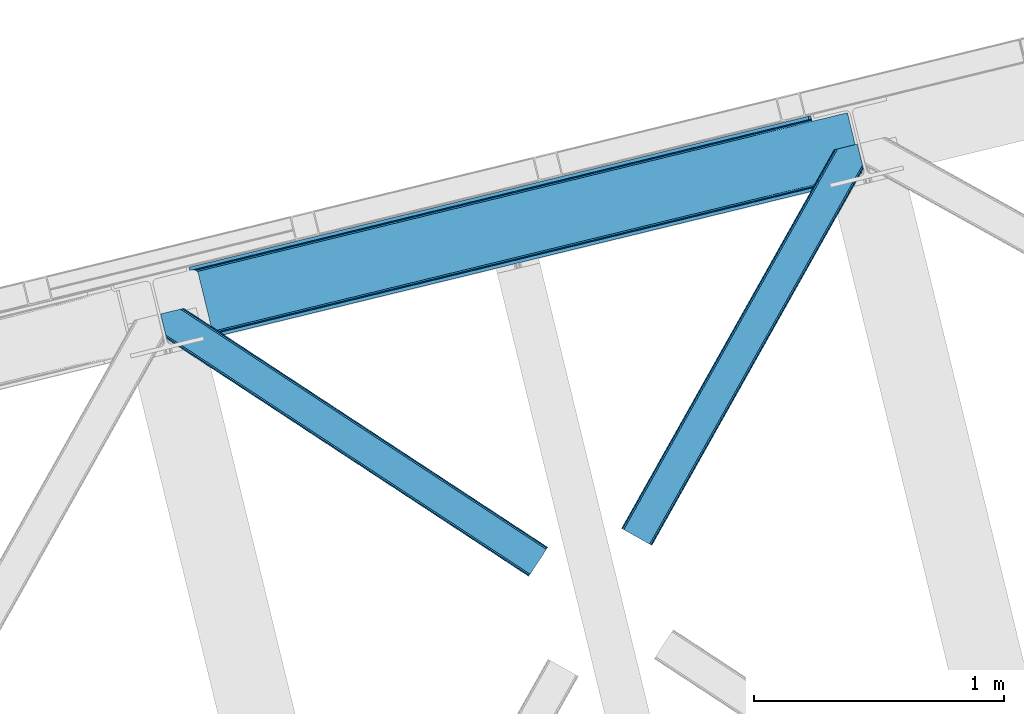
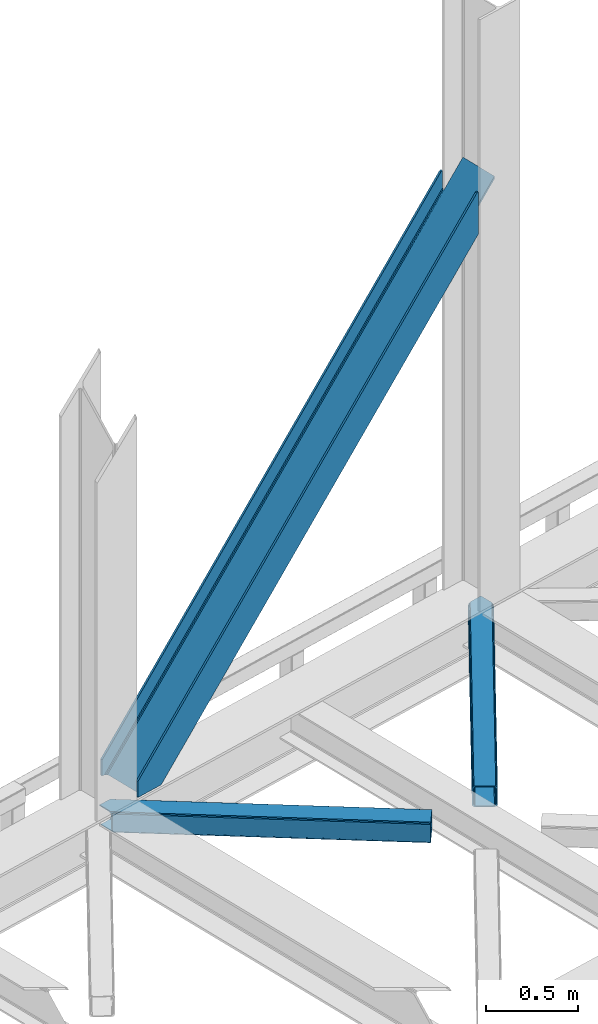
# One storey, part 80 of 93: 3 members.
"""IFC4 building model written with IfcOpenShell, lengths in millimetres."""

from ifc_helpers import new_model, entity, si_unit, converted_unit, derived_unit, direction, frame, origin, place, context, subcontext, project, spatial, triangles, polygons, type_object, element, save


model = new_model("IFC4")

# Units and contexts
model_context = context("Model", 3, precision=0.01, world=origin(), true_north=direction((6.12303176911189e-17, 1.0)))
plan_context = context("Plan", 3, precision=0.01, world=origin(), true_north=direction((6.12303176911189e-17, 1.0)))
body_context = subcontext(model_context, "Body", "Model", "MODEL_VIEW")
ifc_project = project(units=[si_unit("LENGTHUNIT", "METRE", prefix="MILLI"), si_unit("AREAUNIT", "SQUARE_METRE"), si_unit("VOLUMEUNIT", "CUBIC_METRE"), converted_unit("PLANEANGLEUNIT", "DEGREE", entity("IfcRatioMeasure", 0.0174532925199433), si_unit("PLANEANGLEUNIT", "RADIAN"), dimensions=[0, 0, 0, 0, 0, 0, 0]), si_unit("MASSUNIT", "GRAM", prefix="KILO"), derived_unit("MASSDENSITYUNIT", [(si_unit("MASSUNIT", "GRAM", prefix="KILO"), 1), (si_unit("LENGTHUNIT", "METRE"), -3)]), derived_unit("MOMENTOFINERTIAUNIT", [(si_unit("LENGTHUNIT", "METRE"), 4)]), si_unit("TIMEUNIT", "SECOND"), si_unit("FREQUENCYUNIT", "HERTZ"), si_unit("THERMODYNAMICTEMPERATUREUNIT", "DEGREE_CELSIUS"), derived_unit("THERMALTRANSMITTANCEUNIT", [(si_unit("MASSUNIT", "GRAM", prefix="KILO"), 1), (si_unit("THERMODYNAMICTEMPERATUREUNIT", "KELVIN"), -1), (si_unit("TIMEUNIT", "SECOND"), -3)]), derived_unit("VOLUMETRICFLOWRATEUNIT", [(si_unit("LENGTHUNIT", "METRE"), 3), (si_unit("TIMEUNIT", "SECOND"), -1)]), derived_unit("MASSFLOWRATEUNIT", [(si_unit("MASSUNIT", "GRAM", prefix="KILO"), 1), (si_unit("TIMEUNIT", "SECOND"), -1)]), derived_unit("ROTATIONALFREQUENCYUNIT", [(si_unit("TIMEUNIT", "SECOND"), -1)]), si_unit("ELECTRICCURRENTUNIT", "AMPERE"), si_unit("ELECTRICVOLTAGEUNIT", "VOLT"), si_unit("POWERUNIT", "WATT"), si_unit("FORCEUNIT", "NEWTON", prefix="KILO"), si_unit("ILLUMINANCEUNIT", "LUX"), si_unit("LUMINOUSFLUXUNIT", "LUMEN"), si_unit("LUMINOUSINTENSITYUNIT", "CANDELA"), derived_unit("USERDEFINED", [(si_unit("MASSUNIT", "GRAM", prefix="KILO"), -1), (si_unit("LENGTHUNIT", "METRE"), -2), (si_unit("TIMEUNIT", "SECOND"), 3), (si_unit("LUMINOUSFLUXUNIT", "LUMEN"), 1)]), derived_unit("LINEARVELOCITYUNIT", [(si_unit("LENGTHUNIT", "METRE"), 1), (si_unit("TIMEUNIT", "SECOND"), -1)]), si_unit("PRESSUREUNIT", "PASCAL"), derived_unit("USERDEFINED", [(si_unit("LENGTHUNIT", "METRE"), -2), (si_unit("MASSUNIT", "GRAM", prefix="KILO"), 1), (si_unit("TIMEUNIT", "SECOND"), -2)]), derived_unit("LINEARFORCEUNIT", [(si_unit("MASSUNIT", "GRAM", prefix="KILO"), 1), (si_unit("LENGTHUNIT", "METRE"), 1), (si_unit("TIMEUNIT", "SECOND"), -2), (si_unit("LENGTHUNIT", "METRE"), -1)]), derived_unit("PLANARFORCEUNIT", [(si_unit("MASSUNIT", "GRAM", prefix="KILO"), 1), (si_unit("LENGTHUNIT", "METRE"), 1), (si_unit("TIMEUNIT", "SECOND"), -2), (si_unit("LENGTHUNIT", "METRE"), -2)])], contexts=[model_context, plan_context])

# Site, building, storey
site_placement = place(None, origin())
site = spatial("IfcSite", under=ifc_project, at=site_placement, CompositionType="ELEMENT")
building_placement = place(site_placement, origin())
building = spatial("IfcBuilding", under=site, at=building_placement, CompositionType="ELEMENT")
storey_placement = place(building_placement, frame((0.0, 0.0, 15900.0)))
storey = spatial("IfcBuildingStorey", under=building, at=storey_placement, CompositionType="ELEMENT", Elevation=15900.0)

# Members
member_type_1 = type_object("IfcMemberType", PredefinedType="BRACE")
member_1_placement = place(storey_placement, frame((-8823.81342165989, 18506.6610810935, 3695.0)))
element("IfcMember", 1, at=member_1_placement, inside=storey, type_object=member_type_1, ObjectType="Steel Vertical Brace", PredefinedType="BRACE", context=body_context, shape_type="Tessellation", body=[
    polygons([(3.07873920987602, 273.977680396013, 8.22979018266778e-11), (3.07873920888086, 273.977680395771, 106.65765827966), (8.66293703438714e-12, 286.607857151607, 106.65765827966), (1.94699509847851e-09, 286.607857152077, 8.22979018266778e-11), (2479.77214765689, 877.697901605217, 2779.57626168554), (2490.25200805125, 880.252478451081, 2781.6827939859), (2487.17326884237, 892.882655206916, 2781.6827939859), (2476.69340844802, 890.328078361052, 2779.57626168554), (2487.17326884247, 892.882655206941, 2501.09970740511), (169.685130105906, 327.970402848239, 2.16573425859679e-11), (8.63541989623741, 275.332180101836, 7.36349647922907e-11), (430.558974103208, 378.180510303083, 455.352008209132), (868.141546816823, 484.845891934476, 927.60367857852), (1305.72411953044, 591.511273565869, 1399.85534894791), (1743.30669224404, 698.17665519726, 1872.1070193173), (2180.88926495767, 804.842036828657, 2344.35868968668), (2490.25200805127, 880.252478451088, 2678.23184023292), (2490.25200805127, 880.252478451088, 2613.75429495), (2490.25200805132, 880.252478451101, 2501.09970740512), (2490.57649968366, 878.921288507687, 2668.25114832037), (2491.5005736714, 875.130380279116, 2659.78992627632), (2492.62026898089, 870.536957869669, 2654.86848791613), (2492.62026898092, 870.536957869678, 2637.1176472667), (2491.50057367143, 875.130380279123, 2632.1962089066), (2490.57649968368, 878.921288507693, 2623.73498686254), (37.0644416316784, 263.734998293174, 6.064055924071e-11), (33.5935732408485, 269.978935024565, 6.064055924071e-11), (26.9720355143378, 274.375474904885, 6.064055924071e-11), (18.2078975466542, 276.255284592099, 6.49720277579036e-11), (172.76386931478, 315.340226092406, 3.89832166547421e-11), (68.3795180485893, 289.895436106586, 5.63090907235164e-11), (59.4560236630099, 286.30995172954, 5.63090907235164e-11), (52.5400336707846, 280.607944959612, 5.63090907235164e-11), (48.6844448546242, 273.657494638702, 6.064055924071e-11), (48.4762356607877, 266.516743822171, 6.064055924071e-11), (103.656715327513, 40.1451142753133, 5.63090907235164e-11), (107.127583718358, 33.9011775439208, 6.064055924071e-11), (113.74912144486, 29.5046376635999, 5.63090907235164e-11), (122.513259412552, 27.6248279763929, 5.63090907235164e-11), (132.085737062963, 28.5479324666472, 5.63090907235164e-11), (236.470088329151, 53.9927224524679, 3.89832166547421e-11), (239.548827538027, 41.3625456966359, 3.89832166547421e-11), (69.8636974326473, 1.25612586998614e-10, 6.49720277579036e-11), (66.7849582256658, 12.6301767564212, 6.49720277579036e-11), (72.3416389106086, 13.9846764618998, 6.49720277579036e-11), (81.2651332961956, 17.5701608389472, 6.49720277579036e-11), (88.1811232884155, 23.272167608873, 6.064055924071e-11), (92.0367121045813, 30.2226179297901, 6.064055924071e-11), (92.244921298395, 37.3633687463099, 6.49720277579036e-11), (2222.97764830494, 815.101525555878, 2325.30413557918), (1786.65153917481, 708.742420216081, 1854.40847676752), (1350.32543004469, 602.383314876289, 1383.51281795587), (913.999320914564, 496.024209536497, 912.617159144216), (477.673211784457, 389.665104196709, 441.721500332565), (904.938963351569, 482.378592516732, 924.094449451942), (905.606971778055, 475.451429015364, 925.040088653782), (469.280862647932, 369.092323675568, 454.144429842122), (468.61285422145, 376.019487176942, 453.198790640286), (1341.2650724817, 588.73769785653, 1394.99010826359), (1341.93308090818, 581.810534355156, 1395.93574746543), (1777.59118161182, 695.096803196323, 1865.88576707524), (1778.2591900383, 688.169639694948, 1866.83140627709), (2213.91729074194, 801.455908536115, 2336.78142588689), (2214.58529916843, 794.528745034745, 2337.72706508874), (906.299295496529, 488.720797624748, 921.401496842631), (469.973186366417, 382.361692284952, 450.505838030984), (1342.62540462665, 595.079902964541, 1392.29715565429), (1778.95151375678, 701.439008304335, 1863.19281446594), (2215.2776228869, 807.798113644125, 2334.08847327759), (909.480869975318, 493.512501103935, 917.37120844897), (473.154760845203, 387.153395764143, 446.475549637314), (1345.80697910544, 599.871606443729, 1388.26686726062), (1782.13308823556, 706.230711783521, 1859.16252607227), (2218.45919736569, 812.589817123318, 2330.05818488392), (2633.7716358822, 903.743176316763, 2789.55036821242), (2635.38992615553, 897.104324888126, 2791.87149493081), (2633.49531741129, 904.87674135324, 2789.15404241364), (873.308981020911, 484.69522048025, 922.84962927377), (435.726408307295, 378.029838848855, 450.597958904382), (1310.89155373453, 591.36060211164, 1395.10129964316), (1748.47412644814, 698.025983743035, 1867.35297001255), (2186.05669916176, 804.691365374426, 2339.60464038193), (878.338703475162, 481.905107502299, 918.8193408801), (440.756130761546, 375.239725870908, 446.567670510716), (1315.92127618878, 588.570489133689, 1391.07101124949), (1753.50384890239, 695.235870765082, 1863.32268161888), (2191.08642161601, 801.901252396475, 2335.57435198827), (882.464984530468, 476.900322409075, 916.126388270803), (444.882411816845, 370.23494077768, 443.874717901414), (1320.04755724407, 583.565704040466, 1388.37805864019), (1757.63012995769, 690.231085671857, 1860.62972900958), (2195.21270267131, 796.89646730325, 2332.88139937898), (885.059635300978, 470.442798362535, 915.180749068945), (447.477062587366, 363.777416731142, 442.92907869957), (1322.64220801459, 577.108179993928, 1387.43241943833), (1760.22478072821, 683.773561625319, 1859.68408980773), (2197.80735344184, 790.438943256716, 2331.93576017711), (2635.38992615552, 897.104324888122, 2804.1874305464), (2632.79527538494, 903.561848934653, 2805.13306974834), (2632.17672481338, 904.555320457061, 2805.48182008997), (2633.49531741129, 904.876741353238, 2804.18743054672), (2690.5704058222, 670.73269534126, 2804.18743054641), (2692.46501456602, 662.960278876044, 2804.18743054645), (2692.46501456602, 662.960278876044, 2789.15404241398), (2692.18869609554, 664.093843912616, 2789.55036821231), (2690.5704058222, 670.732695341257, 2791.8714949308), (69.8636974321264, -2.16573425859679e-12, 106.65765827966), (66.7849582232532, 12.6301767558321, 106.65765827966), (2546.55710588013, 603.720221209447, 2779.57626168555), (2543.47836667126, 616.350397965279, 2779.57626168555), (2553.95822706562, 618.904974811143, 2781.6827939859), (2553.95822706564, 618.904974811149, 2678.23184023292), (2244.59548397204, 543.494533188718, 2344.35868968668), (1807.01291125842, 436.829151557321, 1872.1070193173), (1369.43033854481, 330.163769925931, 1399.85534894791), (931.847765831195, 223.498388294538, 927.60367857852), (494.26519311758, 116.833006663145, 455.352008209132), (2557.03696627459, 606.274798055334, 2501.09970740512), (2557.03696627449, 606.274798055313, 2781.6827939859), (2553.9582270657, 618.904974811162, 2501.09970740512), (2553.95822706565, 618.904974811149, 2613.75429495), (2553.63373543322, 620.236164754546, 2623.73498686254), (2552.70966144549, 624.027072983117, 2632.1962089066), (2551.58996613549, 628.620495392442, 2637.1176472667), (2551.58996613555, 628.620495392438, 2654.86848791611), (2552.70966144548, 624.027072983114, 2659.78992627632), (2553.6337354332, 620.236164754539, 2668.25114832037), (541.379430798829, 128.317600556771, 441.721500332565), (977.705539928937, 234.676705896559, 912.617159144216), (1414.03164905906, 341.035811236351, 1383.51281795587), (1850.35775818918, 447.394916576147, 1854.40847676752), (2286.68386731931, 553.754021915942, 2325.30413557918), (2269.76577883516, 568.157115487885, 2337.72706508874), (1833.43966970503, 461.798010148093, 1866.83140627708), (1397.11356057491, 355.438904808298, 1395.93574746542), (960.787451444785, 249.079799468504, 925.040088653773), (524.46134231466, 142.72069412871, 454.144429842118), (972.538105724858, 234.827377350792, 917.37120844897), (536.211996594743, 128.468272010997, 446.475549637314), (1408.86421485498, 341.186482690582, 1388.26686726062), (1845.19032398511, 447.545588030378, 1859.16252607227), (2281.51643311522, 553.904693370168, 2330.05818488392), (967.508383270606, 237.61749032874, 921.401496842631), (531.182274140491, 131.25838498895, 450.505838030984), (1403.83449240073, 343.976595668535, 1392.29715565429), (1840.16060153086, 450.335701008331, 1863.19281446594), (2276.48671066098, 556.694806348128, 2334.08847327759), (963.382102215302, 242.622275421964, 924.094449451942), (527.055993085183, 136.263170082167, 453.198790640286), (1399.70821134543, 348.981380761758, 1394.99010826359), (1836.03432047555, 455.340486101554, 1865.88576707524), (2272.36042960567, 561.699591441347, 2336.78142588689), (502.657542254084, 137.40578718428, 442.929078699574), (940.240114967703, 244.071168815673, 915.180749068945), (1377.82268768133, 350.73655044707, 1387.43241943833), (1815.40526039496, 457.401932078467, 1859.68408980771), (2252.98783310858, 564.06731370986, 2331.93576017708), (940.9081233942, 237.144005314307, 916.126388270803), (503.325550680576, 130.47862368291, 443.87471790141), (1378.49069610781, 343.809386945698, 1388.37805864019), (1816.07326882142, 450.474768577091, 1860.62972900958), (2253.65584153503, 557.14015020849, 2332.88139937899), (2691.23841424869, 663.805531839872, 2805.13306974833), (939.547791249238, 230.801800206293, 918.8193408801), (501.965218535623, 124.1364185749, 446.567670510716), (1377.13036396285, 337.46718183769, 1391.07101124949), (1814.71293667646, 444.132563469083, 1863.32268161888), (2252.29550939008, 550.797945100476, 2335.57435198827), (936.36621677045, 226.010096727104, 922.84962927377), (498.783644056835, 119.344715095711, 450.597958904382), (1373.94878948407, 332.675478358499, 1395.10129964316), (1811.53136219768, 439.34085998989, 1867.35297001255), (2249.1139349113, 546.006241621281, 2339.60464038193), (2691.14642196792, 662.638857979852, 2805.48182009003)], [[[1, 2, 3, 4]], [[5, 6, 7, 8]], [[3, 2, 5, 8]], [[4, 3, 8, 7, 9, 10]], [[2, 1, 11, 12, 13, 14, 15, 16, 17, 6, 5]], [[18, 19, 9, 7, 6, 17, 20, 21, 22, 23, 24, 25]], [[26, 27, 28, 29, 11, 1, 4, 10, 30, 31, 32, 33, 34, 35, 36, 37, 38, 39, 40, 41, 42, 43, 44, 45, 46, 47, 48, 49]], [[10, 9, 19, 30]], [[30, 19, 18, 50, 51, 52, 53, 54, 31]], [[55, 56, 57, 58]], [[59, 60, 56, 55]], [[61, 62, 60, 59]], [[63, 64, 62, 61]], [[65, 55, 58, 66]], [[67, 59, 55, 65]], [[68, 61, 59, 67]], [[69, 63, 61, 68]], [[70, 65, 66, 71]], [[72, 67, 65, 70]], [[73, 68, 67, 72]], [[74, 69, 68, 73]], [[53, 70, 71, 54]], [[52, 72, 70, 53]], [[51, 73, 72, 52]], [[50, 74, 73, 51]], [[64, 75, 76]], [[35, 34, 58, 57]], [[34, 33, 66, 58]], [[33, 32, 71, 66]], [[32, 31, 54, 71]], [[18, 25, 74, 50]], [[25, 24, 69, 74]], [[75, 23, 77]], [[63, 24, 23]], [[24, 63, 69]], [[23, 75, 63]], [[75, 64, 63]], [[78, 13, 12, 79]], [[80, 14, 13, 78]], [[81, 15, 14, 80]], [[82, 16, 15, 81]], [[83, 78, 79, 84]], [[85, 80, 78, 83]], [[86, 81, 80, 85]], [[87, 82, 81, 86]], [[88, 83, 84, 89]], [[90, 85, 83, 88]], [[91, 86, 85, 90]], [[92, 87, 86, 91]], [[93, 88, 89, 94]], [[95, 90, 88, 93]], [[96, 91, 90, 95]], [[97, 92, 91, 96]], [[98, 99, 92, 97]], [[21, 20, 82, 87]], [[20, 17, 16, 82]], [[11, 29, 79, 12]], [[29, 28, 84, 79]], [[28, 27, 89, 84]], [[27, 26, 94, 89]], [[22, 99, 100]], [[87, 22, 21]], [[92, 22, 87]], [[22, 92, 99]], [[23, 22, 100, 101, 77]], [[98, 101, 100, 99]], [[101, 98, 102, 103, 104, 105, 106, 76, 75, 77]], [[43, 107, 108, 44]], [[108, 107, 109, 110]], [[44, 108, 110, 111, 112, 113, 114, 115, 116, 117, 45]], [[107, 43, 42, 118, 119, 109]], [[109, 119, 111, 110]], [[112, 111, 119, 118, 120, 121, 122, 123, 124, 125, 126, 127]], [[41, 120, 118, 42]], [[40, 128, 129, 130, 131, 132, 121, 120, 41]], [[35, 57, 56, 60, 62, 64, 76, 106, 133, 134, 135, 136, 137, 36]], [[138, 129, 128, 139]], [[140, 130, 129, 138]], [[141, 131, 130, 140]], [[142, 132, 131, 141]], [[143, 138, 139, 144]], [[145, 140, 138, 143]], [[146, 141, 140, 145]], [[147, 142, 141, 146]], [[148, 143, 144, 149]], [[150, 145, 143, 148]], [[151, 146, 145, 150]], [[152, 147, 146, 151]], [[136, 148, 149, 137]], [[135, 150, 148, 136]], [[134, 151, 150, 135]], [[133, 152, 151, 134]], [[133, 105, 152]], [[123, 122, 142, 147]], [[122, 121, 132, 142]], [[40, 39, 139, 128]], [[39, 38, 144, 139]], [[38, 37, 149, 144]], [[37, 36, 137, 149]], [[124, 105, 104]], [[147, 124, 123]], [[152, 124, 147]], [[124, 152, 105]], [[105, 133, 106]], [[98, 97, 96, 95, 93, 94, 26, 49, 153, 154, 155, 156, 157, 102]], [[158, 154, 153, 159]], [[160, 155, 154, 158]], [[161, 156, 155, 160]], [[162, 157, 156, 161]], [[163, 102, 157, 162]], [[164, 158, 159, 165]], [[166, 160, 158, 164]], [[167, 161, 160, 166]], [[168, 162, 161, 167]], [[169, 164, 165, 170]], [[171, 166, 164, 169]], [[172, 167, 166, 171]], [[173, 168, 167, 172]], [[116, 169, 170, 117]], [[115, 171, 169, 116]], [[114, 172, 171, 115]], [[113, 173, 172, 114]], [[112, 127, 173, 113]], [[127, 126, 168, 173]], [[162, 125, 174, 163]], [[49, 48, 159, 153]], [[48, 47, 165, 159]], [[47, 46, 170, 165]], [[46, 45, 117, 170]], [[168, 125, 162]], [[125, 168, 126]], [[104, 103, 174, 125, 124]], [[174, 103, 102, 163]]], closed=True),
])
member_type_2 = type_object("IfcMemberType", PredefinedType="BRACE")
member_2_placement = place(storey_placement, frame((-8936.90333862305, 17557.1608886719, 3510.00011901855)))
element("IfcMember", 2, at=member_2_placement, inside=storey, type_object=member_type_2, ObjectType="Steel Horizontal Brace", PredefinedType="BRACE", context=body_context, shape_type="Tessellation", body=[
    triangles([(1548.83743743897, 117.035879516603, 122.500662231447), (1548.83743743897, 117.035879516603, 17.5000946044929), (93.3082580566406, 1072.51941833496, 122.500662231447), (93.3082580566406, 1072.51941833496, 17.5000946044929), (1539.23453521729, 102.405377197265, 139.999594116212), (1542.91047363281, 108.005035400391, 138.667117309571), (78.9527389526374, 1069.01963195801, 138.667117309571), (70.0556076049816, 1066.85115966797, 139.999594116212), (1546.02365570068, 112.750094604493, 134.874325561526), (86.4987899780281, 1070.85905456543, 134.874325561526), (1548.10841217041, 115.921994018554, 129.197927856447), (91.5368545532237, 1072.08804931641, 129.197927856447), (18.1488922119152, 975.320700073244, 139.999594116212), (0.0, 1049.77429504395, 139.999594116212), (1481.61595916748, 14.6293395996108, 139.999594116212), (1472.01247558594, 0.0, 122.500662231447), (1472.74150085449, 1.11272277832177, 129.197927856447), (24.2235214233406, 950.398965454104, 122.500662231447), (23.761340332032, 952.295361328124, 129.197927856447), (1474.82218780518, 4.28462219238281, 134.874325561526), (22.4445602416999, 957.698519897462, 134.874325561526), (1477.94002075195, 9.03084411621239, 138.667117309571), (20.4737503051765, 965.782910156249, 138.667117309571), (1472.01247558594, 0.0, 17.5000946044929), (24.2235214233406, 950.398965454104, 17.5000946044929), (1546.02365570068, 112.750094604493, 5.12526855468968), (1542.91047363281, 108.005035400391, 1.33247680664135), (168.079856872559, 1010.51157531739, 1.33247680664135), (166.329963684082, 1017.69020690918, 4.52065429687718), (1548.10841217041, 115.921994018554, 10.8028289794929), (165.5428024292, 1018.81804504395, 5.02062377929906), (164.75099029541, 1019.94588317871, 5.52059326172093), (91.5368545532237, 1072.08804931641, 10.8028289794929), (87.0045730590828, 1070.98230285645, 5.52059326172093), (1539.23453521729, 102.405377197265, 0.0), (170.404133605958, 1000.97494812012, 0.0), (197.80304260254, 888.574832153321, 0.0), (163.159226989746, 880.129998779299, 0.0), (1481.61595916748, 14.6293395996108, 0.0), (196.831590270996, 888.337637329103, 5.52059326172093), (146.210261535645, 875.997692871093, 5.52059326172093), (154.262095642091, 877.960363769533, 1.33247680664135), (197.80304260254, 888.574832153321, 4.52065429687718), (23.9723739624023, 951.429135131835, 12.5201660156272), (25.5711135864258, 951.450064086916, 10.9621215820334), (1472.74150085449, 1.11272277832177, 10.8028289794929), (1474.82218780518, 4.28462219238281, 5.12526855468968), (31.1539123535167, 951.523315429688, 5.52059326172093), (1477.94002075195, 9.03084411621239, 1.33247680664135), (6.80016632080151, 1051.43233337402, 5.52059326172093), (22.4835113525387, 980.848269653321, 6.99957275390625), (23.177655029298, 972.383670043946, 8.3320495605476), (5.36304473876953, 1051.08235473633, 6.99957275390625), (20.1470260620117, 967.122363281251, 12.5201660156272), (60.7521057128906, 1064.58385620117, 6.99957275390625), (1535.39523468018, 96.5545715332046, 6.99957275390625), (1485.45525970459, 20.4813079833984, 6.99957275390625), (1481.77932128906, 14.8816497802727, 8.3320495605476), (1478.66613922119, 10.1365905761741, 12.1260040283232), (21.3312561035164, 962.264520263674, 17.8035644531265), (1475.85235748291, 5.85196838379125, 24.4996673583992), (1476.58138275146, 6.96469116210938, 17.8035644531265), (21.7934371948249, 960.366961669923, 24.4996673583992), (1539.0711730957, 102.153067016603, 8.3320495605476), (69.6533065795902, 1066.75349121094, 8.3320495605476), (1542.18435516357, 106.899288940429, 12.1260040283232), (77.1952880859371, 1068.59175109863, 12.1260040283232), (1544.2644607544, 110.070025634766, 17.8035644531265), (82.2380035400402, 1069.82074584961, 17.8035644531265), (1544.99813690186, 111.183911132812, 24.4996673583992), (84.0047561645515, 1070.25095214844, 24.4996673583992), (1544.99813690186, 111.183911132812, 115.501089477541), (84.0047561645515, 1070.25095214844, 115.501089477541), (77.1952880859371, 1068.59175109863, 127.87475280762), (69.6533065795902, 1066.75349121094, 131.667544555665), (82.2380035400402, 1069.82074584961, 122.196029663086), (60.7521057128906, 1064.58385620117, 133.000021362306), (0.0, 1049.77429504395, 133.000021362306), (1544.2644607544, 110.070025634766, 122.196029663086), (1542.18435516357, 106.899288940429, 127.87475280762), (1539.0711730957, 102.153067016603, 131.667544555665), (1535.39523468018, 96.5545715332046, 133.000021362306), (1478.66613922119, 10.1365905761741, 127.87475280762), (1485.45525970459, 20.4813079833984, 133.000021362306), (1481.77932128906, 14.8816497802727, 131.667544555665), (1475.85235748291, 5.85196838379125, 115.501089477541), (1476.58138275146, 6.96469116210938, 122.196029663086), (21.3312561035164, 962.264520263674, 122.196029663086), (20.0144760131843, 967.666516113281, 127.87475280762), (21.7934371948249, 960.366961669923, 115.501089477541), (18.0436660766609, 975.752069091799, 131.667544555665), (15.7188079833995, 985.288696289063, 133.000021362306)], [[1, 2, 3], [4, 3, 2], [5, 6, 7], [7, 8, 5], [6, 9, 10], [10, 7, 6], [9, 11, 12], [12, 10, 9], [11, 1, 3], [3, 12, 11], [8, 13, 5], [8, 14, 13], [15, 5, 13], [16, 17, 18], [19, 18, 17], [17, 20, 19], [21, 19, 20], [20, 22, 21], [23, 21, 22], [22, 15, 23], [13, 23, 15], [24, 16, 25], [18, 25, 16], [26, 27, 28], [28, 29, 26], [30, 26, 31], [30, 32, 33], [34, 33, 32], [29, 31, 26], [27, 35, 36], [36, 28, 27], [2, 30, 4], [33, 4, 30], [37, 36, 35], [38, 37, 39], [35, 39, 37], [38, 40, 37], [41, 38, 42], [37, 40, 43], [38, 41, 40], [29, 36, 43], [36, 29, 28], [37, 43, 36], [24, 44, 45], [24, 25, 44], [46, 45, 41], [41, 47, 46], [45, 48, 41], [47, 41, 42], [39, 49, 38], [42, 38, 49], [42, 49, 47], [45, 46, 24], [48, 34, 32], [34, 48, 50], [32, 41, 48], [40, 41, 32], [48, 51, 50], [51, 48, 52], [53, 50, 51], [54, 52, 48], [45, 44, 54], [45, 54, 48], [55, 51, 56], [55, 53, 51], [57, 56, 51], [58, 52, 54], [59, 54, 60], [61, 62, 63], [60, 63, 62], [60, 62, 59], [54, 59, 58], [58, 57, 52], [51, 52, 57], [56, 64, 65], [65, 55, 56], [64, 66, 67], [67, 65, 64], [66, 68, 69], [69, 67, 66], [68, 70, 71], [71, 69, 68], [70, 72, 73], [73, 71, 70], [74, 75, 7], [10, 74, 7], [76, 10, 12], [76, 3, 73], [10, 76, 74], [3, 76, 12], [75, 8, 7], [14, 77, 78], [14, 8, 77], [75, 77, 8], [3, 71, 73], [34, 67, 69], [69, 71, 4], [4, 71, 3], [69, 33, 34], [33, 69, 4], [50, 55, 34], [55, 65, 34], [65, 67, 34], [50, 53, 55], [72, 79, 73], [76, 73, 79], [79, 80, 76], [74, 76, 80], [80, 81, 74], [75, 74, 81], [81, 82, 75], [77, 75, 82], [11, 80, 79], [72, 2, 1], [11, 79, 1], [11, 9, 80], [79, 72, 1], [80, 9, 6], [82, 5, 15], [5, 81, 6], [81, 5, 82], [81, 80, 6], [30, 66, 26], [70, 2, 72], [2, 68, 30], [68, 2, 70], [30, 68, 66], [35, 56, 39], [27, 26, 66], [66, 64, 27], [64, 56, 35], [35, 27, 64], [83, 22, 20], [15, 84, 82], [15, 85, 84], [85, 15, 22], [83, 85, 22], [86, 16, 24], [17, 87, 83], [20, 17, 83], [87, 17, 16], [86, 87, 16], [49, 59, 47], [39, 56, 57], [57, 58, 39], [58, 59, 49], [49, 39, 58], [46, 47, 59], [24, 61, 86], [62, 24, 46], [24, 62, 61], [62, 46, 59], [88, 21, 89], [90, 63, 18], [19, 88, 18], [88, 19, 21], [88, 90, 18], [63, 25, 18], [60, 54, 44], [44, 25, 60], [63, 60, 25], [91, 23, 13], [14, 92, 13], [78, 92, 14], [91, 89, 23], [23, 89, 21], [92, 91, 13], [92, 77, 82], [77, 92, 78], [82, 84, 92], [84, 85, 91], [91, 92, 84], [85, 83, 89], [89, 91, 85], [83, 87, 88], [88, 89, 83], [87, 86, 90], [90, 88, 87], [86, 61, 90], [63, 90, 61]]),
])
member_type_3 = type_object("IfcMemberType", PredefinedType="BRACE")
member_3_placement = place(storey_placement, frame((-7093.94780731201, 17681.0521636963, 3510.00011901855)))
element("IfcMember", 3, at=member_3_placement, inside=storey, type_object=member_type_3, ObjectType="Steel Horizontal Brace", PredefinedType="BRACE", context=body_context, shape_type="Tessellation", body=[
    triangles([(963.930697631836, 1521.10947875976, 138.667117309571), (961.605839538574, 1530.64726867676, 139.999594116212), (106.81092224121, 8.56924438476563, 139.999594116212), (112.646612548828, 5.28921203613208, 138.667117309571), (965.901507568359, 1513.02392578125, 134.874325561526), (117.598635864258, 2.50914916992042, 134.874325561526), (967.218287658691, 1507.62192993164, 129.197927856447), (120.904829406738, 0.651123046875, 129.197927856447), (967.681050109863, 1505.72553405762, 122.500662231447), (122.068711853027, 0.0, 122.500662231447), (967.681050109863, 1505.72553405762, 17.5000946044929), (122.068711853027, 0.0, 17.5000946044929), (15.2577896118164, 59.9835479736321, 139.999594116212), (873.405990600586, 1588.02516174316, 139.999594116212), (943.45694732666, 1605.10086364746, 139.999594116212), (851.920092773437, 1582.787109375, 129.197927856447), (850.14868927002, 1582.35574035644, 122.500662231447), (1.15981292724609, 67.8993438720681, 129.197927856447), (0.0, 68.5527923583977, 122.500662231447), (856.962808227539, 1584.0172668457, 134.874325561526), (4.47007598876917, 66.04248046875, 134.874325561526), (864.504208374024, 1585.8555267334, 138.667117309571), (9.41802978515625, 63.2624176025383, 138.667117309571), (850.14868927002, 1582.35574035644, 17.5000946044929), (0.0, 68.5527923583977, 17.5000946044929), (1.15981292724609, 67.8993438720681, 10.8028289794929), (851.920092773437, 1582.787109375, 10.8028289794929), (810.913293457031, 1502.80361938477, 5.52059326172093), (4.47007598876917, 66.04248046875, 5.12526855468968), (810.772023010254, 1501.75252075195, 5.13573303222802), (856.451792907715, 1583.89285583496, 5.52059326172093), (810.640054321289, 1500.7432800293, 4.7659881591826), (810.549362182617, 1500.07355346679, 4.52065429687718), (9.41802978515625, 63.2624176025383, 1.33247680664135), (812.299255371094, 1492.894921875, 1.33247680664135), (814.624113464355, 1483.35829467773, 0.0), (15.2577896118164, 59.9835479736321, 0.0), (842.022441101074, 1370.95817871093, 0.0), (106.81092224121, 8.56924438476563, 0.0), (876.666256713867, 1379.40301208496, 0.0), (893.620454406738, 1383.53648071289, 5.52059326172093), (885.56803894043, 1381.57264709473, 1.33247680664135), (842.993893432617, 1371.19537353516, 5.52059326172093), (842.022441101074, 1370.95817871093, 4.52065429687718), (117.598635864258, 2.50914916992042, 5.12526855468968), (112.646612548828, 5.28921203613208, 1.33247680664135), (966.000920104981, 1506.03830566406, 10.9621215820334), (120.904829406738, 0.651123046875, 10.8028289794929), (967.429902648925, 1506.75570373535, 12.5201660156272), (961.010527038574, 1503.53380737305, 5.52059326172093), (936.65678100586, 1603.44282531738, 5.52059326172093), (963.604554748535, 1522.44893188476, 12.5201660156272), (958.492657470703, 1525.72547607422, 8.3320495605476), (955.213787841797, 1533.55988159179, 6.99957275390625), (938.093321228027, 1603.79280395508, 6.99957275390625), (21.3638122558596, 56.5558502197237, 6.99957275390625), (882.70484161377, 1590.29130249023, 6.99957275390625), (100.704899597168, 11.9957794189431, 6.99957275390625), (111.497264099121, 5.9380096435525, 12.1260040283232), (114.803457641601, 4.07998352050708, 17.8035644531265), (964.788784790039, 1517.59108886719, 17.8035644531265), (106.544659423828, 8.71690979003688, 8.3320495605476), (965.250965881348, 1515.69353027343, 24.4996673583992), (115.962689208985, 3.4265350341775, 24.4996673583992), (965.250965881348, 1515.69353027343, 115.501089477541), (115.962689208985, 3.4265350341775, 115.501089477541), (964.788784790039, 1517.59108886719, 122.196029663086), (963.472004699707, 1522.9930847168, 127.87475280762), (961.50061340332, 1531.07863769531, 131.667544555665), (959.176336669922, 1540.61526489258, 133.000021362306), (943.45694732666, 1605.10086364746, 133.000021362306), (114.803457641601, 4.07998352050708, 122.196029663086), (111.497264099121, 5.9380096435525, 127.87475280762), (106.544659423828, 8.71690979003688, 131.667544555665), (100.704899597168, 11.9957794189431, 133.000021362306), (21.3638122558596, 56.5558502197237, 133.000021362306), (882.70484161377, 1590.29130249023, 133.000021362306), (10.5714477539059, 62.6147827148416, 127.87475280762), (15.5240524291994, 59.8347198486299, 131.667544555665), (6.10137176513672, 65.1239318847656, 115.501089477541), (7.2652542114256, 64.4728088378906, 122.196029663086), (10.5714477539059, 62.6147827148416, 12.1260040283232), (15.5240524291994, 59.8347198486299, 8.3320495605476), (6.10137176513672, 65.1239318847656, 24.4996673583992), (7.2652542114256, 64.4728088378906, 17.8035644531265), (873.807710266113, 1588.12283020019, 131.667544555665), (866.261659240722, 1586.28340759277, 127.87475280762), (861.223594665527, 1585.05557556152, 122.196029663086), (859.45219116211, 1584.62420654297, 115.501089477541), (873.807710266113, 1588.12283020019, 8.3320495605476), (861.223594665527, 1585.05557556152, 17.8035644531265), (866.261659240722, 1586.28340759277, 12.1260040283232), (859.45219116211, 1584.62420654297, 24.4996673583992)], [[1, 2, 3], [3, 4, 1], [5, 1, 4], [4, 6, 5], [7, 5, 6], [6, 8, 7], [9, 7, 8], [8, 10, 9], [11, 9, 10], [10, 12, 11], [13, 2, 14], [13, 3, 2], [2, 15, 14], [16, 17, 18], [19, 18, 17], [20, 16, 21], [18, 21, 16], [22, 20, 23], [21, 23, 20], [14, 22, 13], [23, 13, 22], [17, 24, 19], [25, 19, 24], [26, 27, 28], [28, 29, 26], [28, 30, 29], [27, 31, 28], [29, 30, 32], [33, 34, 29], [33, 35, 34], [35, 36, 34], [37, 34, 36], [24, 27, 26], [26, 25, 24], [38, 37, 36], [39, 38, 40], [38, 39, 37], [40, 41, 42], [40, 38, 43], [40, 43, 41], [43, 38, 44], [36, 33, 44], [36, 35, 33], [44, 38, 36], [45, 46, 42], [47, 48, 41], [48, 45, 41], [12, 48, 47], [47, 49, 12], [49, 11, 12], [41, 50, 47], [42, 41, 45], [40, 42, 46], [46, 39, 40], [41, 28, 50], [41, 43, 28], [31, 50, 28], [51, 50, 31], [52, 50, 53], [49, 47, 52], [52, 47, 50], [54, 50, 51], [50, 54, 53], [51, 55, 54], [56, 54, 57], [56, 58, 54], [54, 55, 57], [59, 60, 61], [61, 52, 59], [62, 59, 52], [53, 54, 58], [58, 62, 53], [52, 53, 62], [63, 61, 60], [60, 64, 63], [65, 63, 66], [64, 66, 63], [61, 49, 52], [9, 11, 63], [11, 61, 63], [63, 65, 9], [11, 49, 61], [67, 9, 65], [7, 9, 67], [5, 67, 68], [67, 5, 7], [68, 1, 5], [69, 1, 68], [69, 70, 2], [69, 2, 1], [70, 15, 2], [70, 71, 15], [67, 65, 72], [66, 72, 65], [68, 67, 73], [72, 73, 67], [69, 68, 74], [73, 74, 68], [70, 69, 75], [74, 75, 69], [76, 70, 75], [70, 76, 77], [71, 70, 77], [8, 73, 72], [66, 12, 10], [8, 72, 10], [8, 6, 73], [72, 66, 10], [73, 6, 4], [75, 3, 13], [3, 74, 4], [74, 3, 75], [74, 73, 4], [48, 59, 45], [64, 12, 66], [12, 60, 48], [60, 12, 64], [48, 60, 59], [39, 58, 37], [46, 45, 59], [59, 62, 46], [62, 58, 39], [39, 46, 62], [78, 23, 21], [13, 76, 75], [13, 79, 76], [79, 13, 23], [78, 79, 23], [80, 19, 25], [18, 81, 78], [21, 18, 78], [81, 18, 19], [80, 81, 19], [34, 82, 29], [37, 58, 56], [56, 83, 37], [83, 82, 34], [34, 37, 83], [26, 29, 82], [25, 84, 80], [85, 25, 26], [25, 85, 84], [85, 26, 82], [22, 14, 86], [15, 77, 14], [77, 15, 71], [77, 86, 14], [87, 22, 86], [87, 20, 22], [20, 88, 16], [88, 20, 87], [17, 88, 89], [88, 17, 16], [57, 31, 90], [91, 92, 31], [92, 90, 31], [57, 51, 31], [51, 57, 55], [93, 91, 24], [27, 24, 91], [17, 93, 24], [93, 17, 89], [91, 31, 27], [91, 93, 85], [84, 85, 93], [92, 91, 82], [85, 82, 91], [90, 92, 83], [82, 83, 92], [57, 90, 56], [83, 56, 90], [93, 89, 84], [80, 84, 89], [86, 77, 76], [76, 79, 86], [87, 86, 79], [79, 78, 87], [88, 87, 78], [78, 81, 88], [89, 88, 81], [81, 80, 89]]),
])

save(model, "model.ifc")
